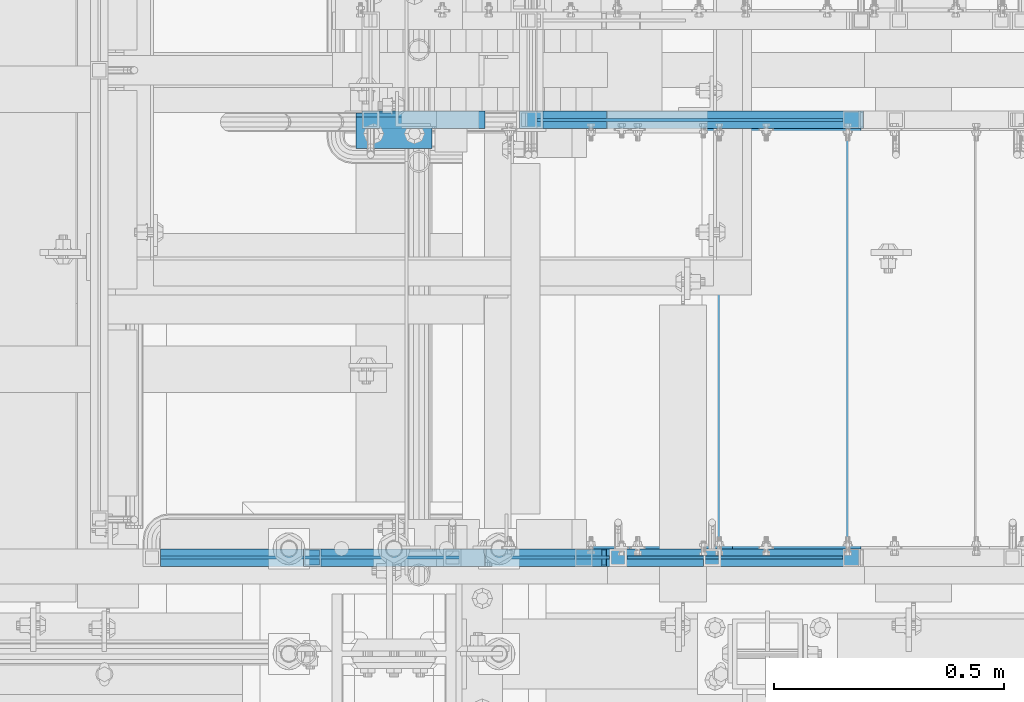
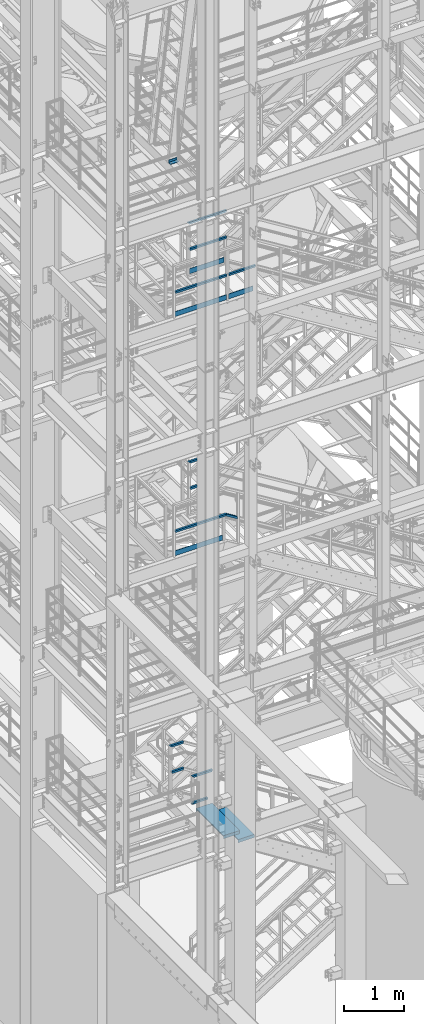
# One storey, part 1136 of 1876: 18 beams, 1 member, 8 elements without a shape of their own.
"""IFC2X3 building model written with IfcOpenShell, lengths in millimetres."""

from ifc_helpers import new_model, si_unit, frame, origin_with_axes, place, context, subcontext, project, spatial, faceted_brep, material, type_object, element, aggregate, save


model = new_model("IFC2X3")

# Units and contexts
model_context = context("Model", 3, precision=1e-05, world=origin_with_axes())
body_context = subcontext(model_context, "Body", "Model", "MODEL_VIEW")
ifc_project = project(units=[si_unit("LENGTHUNIT", "METRE", prefix="MILLI"), si_unit("AREAUNIT", "SQUARE_METRE"), si_unit("VOLUMEUNIT", "CUBIC_METRE"), si_unit("MASSUNIT", "GRAM", prefix="KILO"), si_unit("TIMEUNIT", "SECOND"), si_unit("PLANEANGLEUNIT", "RADIAN"), si_unit("SOLIDANGLEUNIT", "STERADIAN"), si_unit("THERMODYNAMICTEMPERATUREUNIT", "DEGREE_CELSIUS"), si_unit("LUMINOUSINTENSITYUNIT", "LUMEN")], contexts=[model_context])

# Site, building, storey
site_placement = place(None, origin_with_axes())
site = spatial("IfcSite", under=ifc_project, at=site_placement, CompositionType="ELEMENT")
building_placement = place(site_placement, origin_with_axes())
building = spatial("IfcBuilding", under=site, at=building_placement, Name="Undefined", CompositionType="ELEMENT")
storey_placement = place(building_placement, origin_with_axes())
storey = spatial("IfcBuildingStorey", under=building, at=storey_placement, Name="Undefined", CompositionType="ELEMENT", Elevation=0.0)

# Assembly, beam
assembly_1_placement = place(storey_placement, origin_with_axes())
assembly_1 = element("IfcElementAssembly", 1, at=assembly_1_placement, inside=storey, Name="RAIL", AssemblyPlace="NOTDEFINED", PredefinedType="RIGID_FRAME")
ifc_material_1 = material(Name="STEEL/A36")
beam_type_1 = type_object("IfcBeamType", PredefinedType="NOTDEFINED")
beam_1_placement = place(assembly_1_placement, frame((2703.83000256102, -5949.95000191373, 15658.2768557341), z_axis=(0.0, 0.0, 1.0), x_axis=(-1.0, 0.0, 0.0)))
beam_1 = element("IfcBeam", 2, at=beam_1_placement, type_object=beam_type_1, material=ifc_material_1, Name="PLATE", context=body_context, shape_type="Brep", body=[
    faceted_brep([(0.0, 3.17500000000018, -50.8000000000002), (0.0, 3.17500000000018, 50.8000000000002), (665.480001872476, 3.17500000000018, 50.799999999439), (665.480002482168, 3.17500000000018, -50.8000000005613), (0.0, -3.17500000000018, 50.8000000000002), (665.480001872476, -3.17500000000018, 50.799999999439), (0.0, -3.17500000000018, -50.8000000000002), (665.480002482168, -3.17500000000018, -50.8000000005613)], [[[0, 1, 2, 3]], [[1, 4, 5, 2]], [[4, 6, 7, 5]], [[6, 0, 3, 7]], [[5, 7, 3, 2]], [[6, 4, 1, 0]]]),
])

# Assembly, beams
assembly_2_placement = place(storey_placement, origin_with_axes())
assembly_2 = element("IfcElementAssembly", 3, at=assembly_2_placement, inside=storey, Name="RAIL", AssemblyPlace="NOTDEFINED", PredefinedType="RIGID_FRAME")
beam_2_placement = place(assembly_2_placement, frame((2214.87999930055, -6902.45000038169, 15658.2768555724), z_axis=(0.0, 0.0, 1.0), x_axis=(-1.0, 0.0, 0.0)))
beam_2 = element("IfcBeam", 4, at=beam_2_placement, type_object=beam_type_1, material=ifc_material_1, Name="PLATE", context=body_context, shape_type="Brep", body=[
    faceted_brep([(19.049997819523, 3.17500000000018, -50.7999999999975), (19.049997413123, 3.17500000000018, 50.8000000000011), (995.680000562519, 3.17500000000018, 50.8000000000411), (995.680000562523, 3.17500000000018, -50.7999999999593), (19.049997413123, -3.17500000000018, 50.8000000000011), (995.680000562519, -3.17500000000018, 50.8000000000411), (19.049997819523, -3.17500000000018, -50.7999999999975), (995.680000562523, -3.17500000000018, -50.7999999999593)], [[[0, 1, 2, 3]], [[1, 4, 5, 2]], [[4, 6, 7, 5]], [[6, 0, 3, 7]], [[5, 7, 3, 2]], [[6, 4, 1, 0]]]),
])
beam_3_placement = place(assembly_2_placement, frame((2703.83000254048, -6902.45000191595, 15658.276855763), z_axis=(0.0, 0.0, 1.0), x_axis=(-1.0, 0.0, 0.0)))
beam_3 = element("IfcBeam", 5, at=beam_3_placement, type_object=beam_type_1, material=ifc_material_1, Name="PLATE", context=body_context, shape_type="Brep", body=[
    faceted_brep([(0.0, 3.17500000000018, -50.8000000000002), (0.0, 3.17500000000018, 50.8000000000002), (469.900002024323, 3.17500000001019, 50.8000000002503), (469.900002735477, 3.17500000001019, -50.7999999997501), (0.0, -3.17500000000018, 50.8000000000002), (469.900002037023, -3.17499999999018, 50.8000000002503), (0.0, -3.17500000000018, -50.8000000000002), (469.900002748177, -3.17499999999018, -50.7999999997501)], [[[0, 1, 2, 3]], [[1, 4, 5, 2]], [[4, 6, 7, 5]], [[6, 0, 3, 7]], [[5, 7, 3, 2]], [[6, 4, 1, 0]]]),
])

# Assembly, beam
assembly_3_placement = place(storey_placement, origin_with_axes())
assembly_3 = element("IfcElementAssembly", 6, at=assembly_3_placement, inside=storey, Name="RAIL", AssemblyPlace="NOTDEFINED", PredefinedType="RIGID_FRAME")
beam_4_placement = place(assembly_3_placement, frame((2120.90000128083, -6902.45000114926, 10829.9250047341), z_axis=(0.0, 0.0, 1.0), x_axis=(-1.0, 0.0, 0.0)))
beam_4 = element("IfcBeam", 7, at=beam_4_placement, type_object=beam_type_1, material=ifc_material_1, Name="PLATE", context=body_context, shape_type="Brep", body=[
    faceted_brep([(0.0, 3.17500000000018, -50.8000000000002), (0.0, 3.17500000000018, 50.8000000000002), (901.700000190736, 3.17500000000018, 50.8000000000002), (901.700000190736, 3.17500000000018, -50.8000000000002), (0.0, -3.17500000000018, 50.8000000000002), (901.700000190736, -3.17500000000018, 50.8000000000002), (0.0, -3.17500000000018, -50.8000000000002), (901.700000190736, -3.17500000000018, -50.8000000000002)], [[[0, 1, 2, 3]], [[1, 4, 5, 2]], [[4, 6, 7, 5]], [[6, 0, 3, 7]], [[5, 7, 3, 2]], [[6, 4, 1, 0]]]),
])

# Assembly, beams
assembly_4_placement = place(storey_placement, origin_with_axes())
assembly_4 = element("IfcElementAssembly", 8, at=assembly_4_placement, inside=storey, Name="RAIL", AssemblyPlace="NOTDEFINED", PredefinedType="RIGID_FRAME")
ifc_material_2 = material()
beam_type_2 = type_object("IfcBeamType", Name="HSS1-1/2X1-1/2X1/8", PredefinedType="NOTDEFINED")
beam_5_placement = place(assembly_4_placement, frame((1920.01408886128, -5949.95000114554, 5664.2), z_axis=(0.0, 0.0, 1.0), x_axis=(-1.0, 0.0, 0.0)))
beam_5 = element("IfcBeam", 9, at=beam_5_placement, type_object=beam_type_2, material=ifc_material_2, Name="RAIL", ObjectType="HSS1-1/2X1-1/2X1/8", context=body_context, shape_type="Brep", body=[
    faceted_brep([(4.61079483309095, 15.8749992829999, -15.8749992829999), (4.61079483309095, -15.8749992829999, -15.8749992829999), (224.564083510202, -15.8749992829999, -15.8749992829999), (224.564083510202, 15.8749992829999, -15.8749992829999), (-4.61079482670993, -15.8749992829999, 15.8749992829999), (224.564083510202, -15.8749992829999, 15.8749992829999), (-4.61079482670993, 15.8749992829999, 15.8749992829999), (224.564083510202, 15.8749992829999, 15.8749992829999), (5.5329538267797, 19.0499992349996, -19.0499992350001), (-5.53295382039778, 19.0499992349996, 19.0499992350001), (224.564083510202, 19.0499992349996, 19.0499992349996), (224.564083510202, 19.0499992349996, -19.0499992349996), (-5.53295382039778, -19.0499992349996, 19.0499992350001), (224.564083510202, -19.0499992349996, 19.0499992349996), (5.5329538267797, -19.0499992349996, -19.0499992350001), (224.564083510202, -19.0499992349996, -19.0499992349996)], [[[0, 1, 2, 3]], [[1, 4, 5, 2]], [[4, 6, 7, 5]], [[6, 0, 3, 7]], [[8, 9, 10, 11]], [[9, 12, 13, 10]], [[12, 14, 15, 13]], [[14, 8, 11, 15]], [[13, 15, 11, 10], [5, 7, 3, 2]], [[14, 12, 9, 8], [6, 4, 1, 0]]]),
])
beam_6_placement = place(assembly_4_placement, frame((1676.40000611666, -5949.95000114554, 6197.6), z_axis=(0.0, 0.0, -1.0), x_axis=(1.0, 0.0, 0.0)))
beam_6 = element("IfcBeam", 10, at=beam_6_placement, type_object=beam_type_2, material=ifc_material_2, Name="RAIL", ObjectType="HSS1-1/2X1-1/2X1/8", context=body_context, shape_type="Brep", body=[
    faceted_brep([(-15.875, 15.8749981318675, -15.875), (-15.875, -15.8750000000011, -15.875), (248.22487758359, -15.8749992829999, -15.8749992829999), (248.22487758359, 15.8749992829999, -15.8749992829999), (15.875, -15.8750000000011, 15.875), (239.003287914187, -15.8749992829999, 15.8749992829999), (15.875, 15.8749981318675, 15.875), (239.003287914187, 15.8749992829999, 15.8749992829999), (-19.049999234363, 19.0499992349996, -19.0499992350001), (19.0500000000002, 19.0499992349996, 19.0499992350001), (238.081128919538, 19.0499992349996, 19.0499992349996), (249.147036578239, 19.0499992349996, -19.0499992349996), (19.0500000000002, -19.0499992349996, 19.0499992350001), (238.081128919538, -19.0499992349996, 19.0499992349996), (-19.049999234363, -19.0499992349996, -19.0499992350001), (249.147036578239, -19.0499992349996, -19.0499992349996)], [[[0, 1, 2, 3]], [[1, 4, 5, 2]], [[4, 6, 7, 5]], [[6, 0, 3, 7]], [[8, 9, 10, 11]], [[9, 12, 13, 10]], [[12, 14, 15, 13]], [[14, 8, 11, 15]], [[13, 15, 11, 10], [5, 7, 3, 2]], [[14, 12, 9, 8], [6, 4, 1, 0]]]),
])
aggregate(assembly_4, [beam_5, beam_6])

assembly_5_placement = place(storey_placement, origin_with_axes())
assembly_5 = element("IfcElementAssembly", 11, at=assembly_5_placement, inside=storey, Name="RAIL", AssemblyPlace="NOTDEFINED", PredefinedType="RIGID_FRAME")
beam_7_placement = place(assembly_5_placement, frame((1835.15000687492, -6902.45000114554, 5673.72500000168), z_axis=(0.0, 0.0, 1.0), x_axis=(-1.0, 0.0, 0.0)))
beam_7 = element("IfcBeam", 12, at=beam_7_placement, type_object=beam_type_2, material=ifc_material_2, Name="RAIL", ObjectType="HSS1-1/2X1-1/2X1/8", context=body_context, shape_type="Brep", body=[
    faceted_brep([(-7.27595761418343e-12, 15.8749992829999, -15.8749992829999), (-7.27595761418343e-12, -15.8749992829999, -15.8749992829999), (301.625000041689, -15.8749992829999, -15.8749992829999), (301.625000041689, 15.8749992829999, -15.8749992829999), (5.45696821063757e-12, -15.8749992829999, 15.8749992829999), (269.875001475689, -15.8749992829999, 15.8749992829999), (5.45696821063757e-12, 15.8749992829999, 15.8749992829999), (269.875001475689, 15.8749992829999, 15.8749992829999), (0.0, 19.0499992349996, -19.0499992350001), (0.0, 19.0499992349996, 19.0499992349996), (266.700001523689, 19.0499992349996, 19.0499992349996), (304.799999993689, 19.0499992349996, -19.0499992349996), (0.0, -19.0499992349996, 19.0499992349996), (266.700001523689, -19.0499992349996, 19.0499992349996), (0.0, -19.0499992349996, -19.0499992350001), (304.799999993689, -19.0499992349996, -19.0499992349996)], [[[0, 1, 2, 3]], [[1, 4, 5, 2]], [[4, 6, 7, 5]], [[6, 0, 3, 7]], [[8, 9, 10, 11]], [[9, 12, 13, 10]], [[12, 14, 15, 13]], [[14, 8, 11, 15]], [[13, 15, 11, 10], [5, 7, 3, 2]], [[14, 12, 9, 8], [6, 4, 1, 0]]]),
])
beam_8_placement = place(assembly_5_placement, frame((1549.40000610992, -6902.45000114554, 6207.12500000169), z_axis=(0.0, 0.0, -1.0), x_axis=(1.0, 0.0, 0.0)))
beam_8 = element("IfcBeam", 13, at=beam_8_placement, type_object=beam_type_2, material=ifc_material_2, Name="RAIL", ObjectType="HSS1-1/2X1-1/2X1/8", context=body_context, shape_type="Brep", body=[
    faceted_brep([(-15.875, 15.8749981318675, -15.875), (-15.875, -15.8750000000011, -15.875), (375.22487814284, -15.8749992829999, -15.8749992829999), (375.22487814284, 15.8749992829999, -15.8749992829999), (15.875, -15.8750000000011, 15.875), (366.003288473436, -15.8749992829999, 15.8749992829999), (15.875, 15.8749981318675, 15.875), (366.003288473436, 15.8749992829999, 15.8749992829999), (-19.049999234363, 19.0499992349996, -19.0499992350001), (19.0500000000002, 19.0499992349996, 19.0499992350001), (365.081129478787, 19.0499992349996, 19.0499992349996), (376.147037137488, 19.0499992349996, -19.0499992349996), (19.0500000000002, -19.0499992349996, 19.0499992350001), (365.081129478787, -19.0499992349996, 19.0499992349996), (-19.049999234363, -19.0499992349996, -19.0499992350001), (376.147037137488, -19.0499992349996, -19.0499992349996)], [[[0, 1, 2, 3]], [[1, 4, 5, 2]], [[4, 6, 7, 5]], [[6, 0, 3, 7]], [[8, 9, 10, 11]], [[9, 12, 13, 10]], [[12, 14, 15, 13]], [[14, 8, 11, 15]], [[13, 15, 11, 10], [5, 7, 3, 2]], [[14, 12, 9, 8], [6, 4, 1, 0]]]),
])
aggregate(assembly_5, [beam_7, beam_8])

# Beam
beam_9_placement = place(assembly_3_placement, frame((2184.42256528323, -6902.45000114554, 11274.4249989601), z_axis=(0.0, 0.0, 1.0), x_axis=(-1.0, 0.0, 0.0)))
beam_9 = element("IfcBeam", 14, at=beam_9_placement, type_object=beam_type_2, material=ifc_material_2, Name="RAIL", ObjectType="HSS1-1/2X1-1/2X1/8", context=body_context, shape_type="Brep", body=[
    faceted_brep([(4.49184492398945, 15.8749992829999, -15.8749992829999), (4.49184492398945, -15.8749992829999, -15.8749992829999), (965.222565248988, -15.8749992829999, -15.8749992829999), (965.222565248988, 15.8749992829999, -15.8749992829999), (-4.49184492818313, -15.8749992829999, 15.8749992829999), (965.222565248988, -15.8749992829999, 15.8749992829999), (-4.49184492818313, 15.8749992829999, 15.8749992829999), (965.222565248988, 15.8749992829999, 15.8749992829999), (5.39021393619987, 19.0499992349996, -19.0499992349996), (-5.39021394039355, 19.0499992349996, 19.0499992349996), (965.222565248988, 19.0499992349996, 19.0499992349996), (965.222565248988, 19.0499992349996, -19.0499992349996), (-5.39021394039355, -19.0499992349996, 19.0499992349996), (965.222565248988, -19.0499992349996, 19.0499992349996), (5.39021393619987, -19.0499992349996, -19.0499992349996), (965.222565248988, -19.0499992349996, -19.0499992349996)], [[[0, 1, 2, 3]], [[1, 4, 5, 2]], [[4, 6, 7, 5]], [[6, 0, 3, 7]], [[8, 9, 10, 11]], [[9, 12, 13, 10]], [[12, 14, 15, 13]], [[14, 8, 11, 15]], [[13, 15, 11, 10], [5, 7, 3, 2]], [[14, 12, 9, 8], [6, 4, 1, 0]]]),
])

# Assembly, beams
assembly_6_placement = place(storey_placement, origin_with_axes())
assembly_6 = element("IfcElementAssembly", 15, at=assembly_6_placement, inside=storey, Name="RAIL", AssemblyPlace="NOTDEFINED", PredefinedType="RIGID_FRAME")
beam_10_placement = place(assembly_6_placement, frame((2184.4225652837, -5949.95000114554, 11274.4249989601), z_axis=(0.0, 0.0, 1.0), x_axis=(-1.0, 0.0, 0.0)))
beam_10 = element("IfcBeam", 16, at=beam_10_placement, type_object=beam_type_2, material=ifc_material_2, Name="RAIL", ObjectType="HSS1-1/2X1-1/2X1/8", context=body_context, shape_type="Brep", body=[
    faceted_brep([(4.49184492398945, 15.8749992829999, -15.8749992829999), (4.49184492398945, -15.8749992829999, -15.8749992829999), (133.372565249457, -15.8749992829999, -15.8749992829999), (133.372565249457, 15.8749992829999, -15.8749992829999), (-4.49184492818313, -15.8749992829999, 15.8749992829999), (133.372565249457, -15.8749992829999, 15.8749992829999), (-4.49184492818313, 15.8749992829999, 15.8749992829999), (133.372565249457, 15.8749992829999, 15.8749992829999), (5.39021393619987, 19.0499992349996, -19.0499992349996), (-5.39021394039355, 19.0499992349996, 19.0499992349996), (133.372565249457, 19.0499992349996, 19.0499992349996), (133.372565249457, 19.0499992349996, -19.0499992349996), (-5.39021394039355, -19.0499992349996, 19.0499992349996), (133.372565249457, -19.0499992349996, 19.0499992349996), (5.39021393619987, -19.0499992349996, -19.0499992349996), (133.372565249457, -19.0499992349996, -19.0499992349996)], [[[0, 1, 2, 3]], [[1, 4, 5, 2]], [[4, 6, 7, 5]], [[6, 0, 3, 7]], [[8, 9, 10, 11]], [[9, 12, 13, 10]], [[12, 14, 15, 13]], [[14, 8, 11, 15]], [[13, 15, 11, 10], [5, 7, 3, 2]], [[14, 12, 9, 8], [6, 4, 1, 0]]]),
])
beam_11_placement = place(assembly_6_placement, frame((2032.00000079814, -5949.95000114554, 11807.82499896), z_axis=(0.0, 0.0, -1.0), x_axis=(1.0, 0.0, 0.0)))
beam_11 = element("IfcBeam", 17, at=beam_11_placement, type_object=beam_type_2, material=ifc_material_2, Name="RAIL", ObjectType="HSS1-1/2X1-1/2X1/8", context=body_context, shape_type="Brep", body=[
    faceted_brep([(-15.875, 15.8749981318675, -15.875), (-15.875, -15.8750000000011, -15.875), (156.914430261252, -15.8749992829999, -15.8749992829999), (156.914430261252, 15.8749992829999, -15.8749992829999), (15.875, -15.8750000000011, 15.875), (147.930698712814, -15.8749992829999, 15.8749992829999), (15.875, 15.8749981318675, 15.875), (147.930698712814, 15.8749992829999, 15.8749992829999), (-19.049999234363, 19.0499992349996, -19.0499992350001), (19.0500000000002, 19.0499992349996, 19.0499992350001), (147.032325530977, 19.0499992349996, 19.0499992349996), (157.812803443089, 19.0499992349996, -19.0499992349996), (19.0500000000002, -19.0499992349996, 19.0499992350001), (147.032325530977, -19.0499992349996, 19.0499992349996), (-19.049999234363, -19.0499992349996, -19.0499992350001), (157.812803443089, -19.0499992349996, -19.0499992349996)], [[[0, 1, 2, 3]], [[1, 4, 5, 2]], [[4, 6, 7, 5]], [[6, 0, 3, 7]], [[8, 9, 10, 11]], [[9, 12, 13, 10]], [[12, 14, 15, 13]], [[14, 8, 11, 15]], [[13, 15, 11, 10], [5, 7, 3, 2]], [[14, 12, 9, 8], [6, 4, 1, 0]]]),
])
aggregate(assembly_6, [beam_10, beam_11])

# Beam
beam_12_placement = place(assembly_2_placement, frame((2214.88016467872, -6902.45000114489, 16102.7768506216), z_axis=(0.0, 0.0, 1.0), x_axis=(-1.0, 0.0, 0.0)))
beam_12 = element("IfcBeam", 18, at=beam_12_placement, type_object=beam_type_2, material=ifc_material_2, Name="RAIL", ObjectType="HSS1-1/2X1-1/2X1/8", context=body_context, shape_type="Brep", body=[
    faceted_brep([(19.0500000000002, 15.8749992829999, -15.8749992829999), (19.0500000000002, -15.8749992829999, -15.8749992829999), (995.680000604343, -15.8749992829999, -15.8749992825578), (995.680000604343, 15.8749992829999, -15.8749992825578), (19.0500000000002, -15.8749992829999, 15.8749992829999), (995.680000636107, -15.8749992829999, 15.8749992834419), (19.0500000000002, 15.8749992829999, 15.8749992829999), (995.680000636107, 15.8749992829999, 15.8749992834419), (19.0500000000002, 19.0499992349996, -19.0499992350001), (19.0500000000002, 19.0499992349996, 19.0499992350001), (995.680000639284, 19.0499992349996, 19.0499992354416), (995.680000601167, 19.0499992349996, -19.0499992345576), (19.0500000000002, -19.0499992349996, 19.0499992350001), (995.680000639284, -19.0499992349996, 19.0499992354416), (19.0500000000002, -19.0499992349996, -19.0499992350001), (995.680000601167, -19.0499992349996, -19.0499992345576)], [[[0, 1, 2, 3]], [[1, 4, 5, 2]], [[4, 6, 7, 5]], [[6, 0, 3, 7]], [[8, 9, 10, 11]], [[9, 12, 13, 10]], [[12, 14, 15, 13]], [[14, 8, 11, 15]], [[13, 15, 11, 10], [5, 7, 3, 2]], [[12, 9, 8, 14], [4, 1, 0, 6]]]),
])

beam_13_placement = place(assembly_2_placement, frame((2743.20017002785, -6902.45000114661, 16102.7768506216), z_axis=(0.0, 0.0, 1.0), x_axis=(-1.0, 0.0, 0.0)))
beam_13 = element("IfcBeam", 19, at=beam_13_placement, type_object=beam_type_2, material=ifc_material_2, Name="RAIL", ObjectType="HSS1-1/2X1-1/2X1/8", context=body_context, shape_type="Brep", body=[
    faceted_brep([(4.51892492790421, 15.8749992829999, -15.8749992829999), (4.51892492790421, -15.8749992829999, -15.8749992829999), (509.270006112252, -15.8749992829999, -15.8749992829999), (509.270006112252, 15.8749992829999, -15.8749992829999), (-4.51892492501338, -15.8749992829999, 15.8749992829999), (509.270006112252, -15.8749992829999, 15.8749992829999), (-4.51892492501338, 15.8749992829999, 15.8749992829999), (509.270006112252, 15.8749992829999, 15.8749992829999), (5.42270994035198, 19.0499992349996, -19.0499992349996), (-5.42270993746115, 19.0499992349996, 19.0499992349996), (509.270006112252, 19.0499992349996, 19.0499992349996), (509.270006112252, 19.0499992349996, -19.0499992349996), (-5.42270993746115, -19.0499992349996, 19.0499992349996), (509.270006112252, -19.0499992349996, 19.0499992349996), (5.42270994035198, -19.0499992349996, -19.0499992349996), (509.270006112252, -19.0499992349996, -19.0499992349996)], [[[0, 1, 2, 3]], [[1, 4, 5, 2]], [[4, 6, 7, 5]], [[6, 0, 3, 7]], [[8, 9, 10, 11]], [[9, 12, 13, 10]], [[12, 14, 15, 13]], [[14, 8, 11, 15]], [[13, 15, 11, 10], [5, 7, 3, 2]], [[14, 12, 9, 8], [6, 4, 1, 0]]]),
])

aggregate(assembly_2, [beam_2, beam_3, beam_12, beam_13])

beam_14_placement = place(assembly_1_placement, frame((2743.20016971513, -5949.95000114554, 16102.776850817), z_axis=(0.0, 0.0, 1.0), x_axis=(-1.0, 0.0, 0.0)))
beam_14 = element("IfcBeam", 20, at=beam_14_placement, type_object=beam_type_2, material=ifc_material_2, Name="RAIL", ObjectType="HSS1-1/2X1-1/2X1/8", context=body_context, shape_type="Brep", body=[
    faceted_brep([(4.51892492790421, 15.8749992829999, -15.8749992829999), (4.51892492790421, -15.8749992829999, -15.8749992829999), (704.850005682369, -15.8749992829999, -15.8749992829999), (704.850005682369, 15.8749992829999, -15.8749992829999), (-4.51892492501338, -15.8749992829999, 15.8749992829999), (704.850005682369, -15.8749992829999, 15.8749992829999), (-4.51892492501338, 15.8749992829999, 15.8749992829999), (704.850005682369, 15.8749992829999, 15.8749992829999), (5.42270994035198, 19.0499992349996, -19.0499992349996), (-5.42270993746115, 19.0499992349996, 19.0499992349996), (704.850005682369, 19.0499992349996, 19.0499992349996), (704.850005682369, 19.0499992349996, -19.0499992349996), (-5.42270993746115, -19.0499992349996, 19.0499992349996), (704.850005682369, -19.0499992349996, 19.0499992349996), (5.42270994035198, -19.0499992349996, -19.0499992349996), (704.850005682369, -19.0499992349996, -19.0499992349996)], [[[0, 1, 2, 3]], [[1, 4, 5, 2]], [[4, 6, 7, 5]], [[6, 0, 3, 7]], [[8, 9, 10, 11]], [[9, 12, 13, 10]], [[12, 14, 15, 13]], [[14, 8, 11, 15]], [[13, 15, 11, 10], [5, 7, 3, 2]], [[14, 12, 9, 8], [6, 4, 1, 0]]]),
])

beam_15_placement = place(assembly_1_placement, frame((2019.30016479343, -5949.95000114554, 16636.176850817), z_axis=(0.0, 0.0, -1.0), x_axis=(1.0, 0.0, 0.0)))
beam_15 = element("IfcBeam", 21, at=beam_15_placement, type_object=beam_type_2, material=ifc_material_2, Name="RAIL", ObjectType="HSS1-1/2X1-1/2X1/8", context=body_context, shape_type="Brep", body=[
    faceted_brep([(-15.875, 15.8749981318675, -15.875), (-15.875, -15.8750000000011, -15.875), (728.418929841071, -15.8749992829999, -15.8749992830017), (728.418929841071, 15.8749992829999, -15.8749992830017), (15.875, -15.8750000000011, 15.875), (719.381079988153, -15.8749992829999, 15.8749992830017), (15.875, 15.8749981318675, 15.875), (719.381079988153, 15.8749992829999, 15.8749992830017), (-19.049999234363, 19.0499992349996, -19.0499992350001), (19.0500000000002, 19.0499992349996, 19.0499992350001), (718.477294975706, 19.0499992349996, 19.0499992350015), (729.322714853519, 19.0499992349996, -19.0499992350015), (19.0500000000002, -19.0499992349996, 19.0499992350001), (718.477294975706, -19.0499992349996, 19.0499992350015), (-19.049999234363, -19.0499992349996, -19.0499992350001), (729.322714853519, -19.0499992349996, -19.0499992350015)], [[[0, 1, 2, 3]], [[1, 4, 5, 2]], [[4, 6, 7, 5]], [[6, 0, 3, 7]], [[8, 9, 10, 11]], [[9, 12, 13, 10]], [[12, 14, 15, 13]], [[14, 8, 11, 15]], [[13, 15, 11, 10], [5, 7, 3, 2]], [[14, 12, 9, 8], [6, 4, 1, 0]]]),
])

aggregate(assembly_1, [beam_1, beam_14, beam_15])

# Member
member_type = type_object("IfcMemberType", Name="HSS1-1/2X1-1/2X1/8", PredefinedType="NOTDEFINED")
member_placement = place(assembly_3_placement, frame((2419.35000079751, -6902.45000114554, 11129.9082433488), z_axis=(0.523955482879573, 0.0, 0.851745649804232), x_axis=(-0.851745649804232, 0.0, 0.523955482879573)))
member = element("IfcMember", 22, at=member_placement, type_object=member_type, material=ifc_material_2, Name="RAIL", ObjectType="HSS1-1/2X1-1/2X1/8", context=body_context, shape_type="Brep", body=[
    faceted_brep([(12.6002676416374, 15.8749992829999, -15.8749992830035), (12.6002676416374, -15.8749992829999, -15.8749992830035), (271.326901899188, -15.8749992829999, -15.8749992828289), (271.326901899188, 15.8749992829999, -15.8749992828289), (32.1314140629433, -15.8749992829999, 15.8749992830271), (280.31063346521, -15.8749992829999, 15.8749992831908), (32.1314140629433, 15.8749992829999, 15.8749992830271), (280.31063346521, 15.8749992829999, 15.8749992831908), (10.6471616099025, 19.0499992349996, -19.0499992350033), (34.0845307397099, 19.0499992349996, 19.0499992350287), (281.209006648806, 19.0499992349996, 19.0499992351924), (270.428528715591, 19.0499992349996, -19.0499992348323), (34.0845307397099, -19.0499992349996, 19.0499992350287), (281.209006648806, -19.0499992349996, 19.0499992351924), (10.6471616099025, -19.0499992349996, -19.0499992350033), (270.428528715591, -19.0499992349996, -19.0499992348323)], [[[0, 1, 2, 3]], [[1, 4, 5, 2]], [[4, 6, 7, 5]], [[6, 0, 3, 7]], [[8, 9, 10, 11]], [[9, 12, 13, 10]], [[12, 14, 15, 13]], [[14, 8, 11, 15]], [[13, 15, 11, 10], [5, 7, 3, 2]], [[14, 12, 9, 8], [6, 4, 1, 0]]]),
])

aggregate(assembly_3, [beam_4, beam_9, member])

# Assembly, beams
assembly_7_placement = place(storey_placement, origin_with_axes())
assembly_7 = element("IfcElementAssembly", 23, at=assembly_7_placement, inside=storey, Name="STRINGER", AssemblyPlace="NOTDEFINED", PredefinedType="RIGID_FRAME")
beam_type_3 = type_object("IfcBeamType", PredefinedType="NOTDEFINED")
beam_16_placement = place(assembly_7_placement, frame((2309.81250547177, -5973.76300113406, 4776.29482758842), z_axis=(1.0, 0.0, 0.0), x_axis=(0.0, -1.0, 0.0)))
beam_16 = element("IfcBeam", 24, at=beam_16_placement, type_object=beam_type_3, material=ifc_material_1, Name="TREAD", context=body_context, shape_type="Brep", body=[
    faceted_brep([(-7.45785655453801e-11, 53.9750000000167, -153.9875), (-7.45785655453801e-11, 53.9750000000167, 153.987506103515), (0.0, 9.52499999999964, 153.9875), (-7.45785655453801e-11, 9.52499999999964, -153.9875), (-4.76300000007541, 53.9750000000167, -153.9875), (-4.76300000007541, 53.9750000000167, 153.987506103515), (-4.76300000007541, -9.52499999998327, -153.9875), (-4.76300000007541, -9.52500000019427, 153.987536621094), (909.637000008669, -9.52500000248983, 153.987506103515), (909.637000008669, 53.9749999975102, 153.987506103515), (904.87400000867, 53.9749999975102, 153.987506103515), (904.87400000867, 9.52499999999964, 153.987506103515), (-7.45785655453801e-11, -9.52500000019427, 153.987536621094), (904.87400000867, -9.52500000248983, 153.987506103515), (904.87400000867, 9.52499999999964, -153.9875), (909.637000008669, -9.52500000248983, -153.9875), (909.637000008669, 53.9749999975102, -153.9875), (904.87400000867, 53.9749999975102, -153.9875)], [[[0, 1, 2, 3]], [[1, 0, 4, 5]], [[5, 4, 6, 7]], [[8, 9, 10, 11, 2, 1, 5, 7, 12, 13]], [[14, 3, 2, 11]], [[15, 8, 13, 12, 7, 6]], [[9, 16, 17, 10]], [[16, 9, 8, 15]], [[16, 15, 6, 4, 0, 3, 14, 17]], [[10, 17, 14, 11]]]),
])
beam_17_placement = place(assembly_7_placement, frame((2589.21250515397, -5973.7630011339, 4599.04224138178), z_axis=(1.0, 0.0, 0.0), x_axis=(0.0, -1.0, 0.0)))
beam_17 = element("IfcBeam", 25, at=beam_17_placement, type_object=beam_type_3, material=ifc_material_1, Name="TREAD", context=body_context, shape_type="Brep", body=[
    faceted_brep([(-7.45785655453801e-11, 53.9750000000167, -153.9875), (-7.45785655453801e-11, 53.9750000000167, 153.987506103515), (0.0, 9.52499999999964, 153.9875), (-7.45785655453801e-11, 9.52499999999964, -153.9875), (-4.76300000007541, 53.9750000000167, -153.9875), (-4.76300000007541, 53.9750000000167, 153.987506103515), (-4.76300000007541, -9.52499999998327, -153.9875), (-4.76300000007541, -9.52500000019427, 153.987536621094), (909.637000008669, -9.52500000248983, 153.987506103515), (909.637000008669, 53.9749999975102, 153.987506103515), (904.87400000867, 53.9749999975102, 153.987506103515), (904.87400000867, 9.52499999999964, 153.987506103515), (-7.45785655453801e-11, -9.52500000019427, 153.987536621094), (904.87400000867, -9.52500000248983, 153.987506103515), (904.87400000867, 9.52499999999964, -153.9875), (909.637000008669, -9.52500000248983, -153.9875), (909.637000008669, 53.9749999975102, -153.9875), (904.87400000867, 53.9749999975102, -153.9875)], [[[0, 1, 2, 3]], [[1, 0, 4, 5]], [[5, 4, 6, 7]], [[8, 9, 10, 11, 2, 1, 5, 7, 12, 13]], [[14, 3, 2, 11]], [[15, 8, 13, 12, 7, 6]], [[9, 16, 17, 10]], [[16, 9, 8, 15]], [[16, 15, 6, 4, 0, 3, 14, 17]], [[10, 17, 14, 11]]]),
])
aggregate(assembly_7, [beam_16, beam_17])

# Assembly, beam
assembly_8_placement = place(storey_placement, origin_with_axes())
assembly_8 = element("IfcElementAssembly", 26, at=assembly_8_placement, inside=storey, Name="RIGHT STRINGER", AssemblyPlace="NOTDEFINED", PredefinedType="RIGID_FRAME")
beam_type_4 = type_object("IfcBeamType", Name="L3X2X5/16", PredefinedType="NOTDEFINED")
beam_18_placement = place(assembly_8_placement, frame((1809.81497467844, -5973.76250000001, 18008.6), z_axis=(0.0, -1.0, 0.0), x_axis=(-1.0, 0.0, 0.0)))
beam_18 = element("IfcBeam", 27, at=beam_18_placement, type_object=beam_type_4, material=ifc_material_1, Name="ANGLE", ObjectType="L3X2X5/16", context=body_context, shape_type="Brep", body=[
    faceted_brep([(0.0, 25.3999999999996, -38.1000000000004), (0.0, 25.3999999999996, 38.1000000000004), (165.1, 25.4000000000015, 38.1000000000004), (165.1, 25.4000000000015, -38.1000000000004), (0.0, 17.4625000000015, 38.1000000000004), (165.1, 17.4625000000015, 38.1000000000004), (0.0, 17.4625000000015, -30.1625000000004), (165.1, 17.4625000000015, -30.1625000000004), (0.0, -25.4000000000015, -30.1625000000004), (165.1, -25.4000000000015, -30.1625000000004), (0.0, -25.3999999999996, -38.1000000000004), (165.1, -25.4000000000015, -38.1000000000004)], [[[0, 1, 2, 3]], [[1, 4, 5, 2]], [[4, 6, 7, 5]], [[6, 8, 9, 7]], [[8, 10, 11, 9]], [[10, 0, 3, 11]], [[5, 7, 9, 11, 3, 2]], [[10, 8, 6, 4, 1, 0]]]),
])
aggregate(assembly_8, [beam_18])

save(model, "model.ifc")
